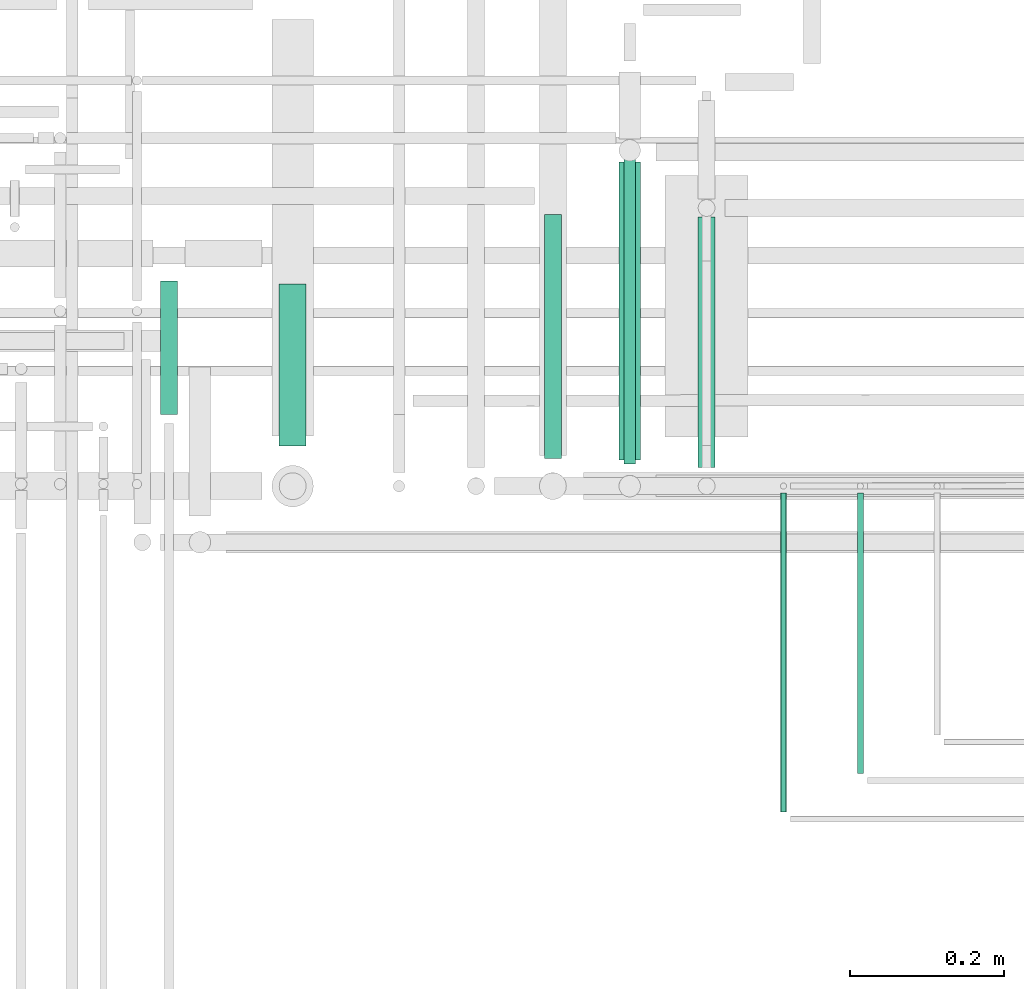
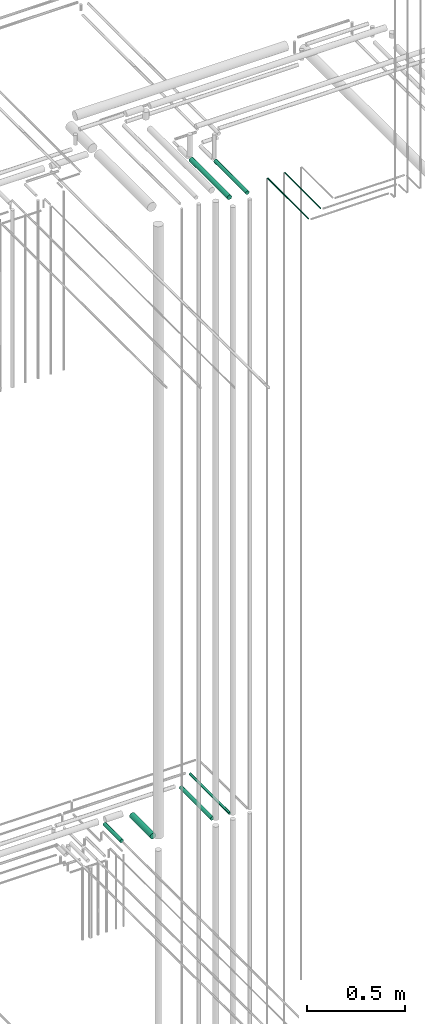
# One storey, part 224 of 331: 8 flow segments.
"""IFC2X3 building model written with IfcOpenShell, lengths in millimetres."""

from ifc_helpers import new_model, entity, si_unit, converted_unit, derived_unit, direction, frame, frame_2d, origin, origin_2d_with_axis, place, context, subcontext, project, spatial, circle, extrude, type_object, element, save


model = new_model("IFC2X3")

# Units and contexts
model_context = context("Model", 3, precision=0.01, world=origin(), true_north=direction((6.12303176911189e-17, 1.0)))
body_context = subcontext(model_context, "Body", "Model", "MODEL_VIEW")
ifc_project = project(units=[si_unit("LENGTHUNIT", "METRE", prefix="MILLI"), si_unit("AREAUNIT", "SQUARE_METRE"), si_unit("VOLUMEUNIT", "CUBIC_METRE"), converted_unit("PLANEANGLEUNIT", "DEGREE", entity("IfcRatioMeasure", 0.0174532925199433), si_unit("PLANEANGLEUNIT", "RADIAN"), dimensions=[0, 0, 0, 0, 0, 0, 0]), si_unit("MASSUNIT", "GRAM", prefix="KILO"), derived_unit("MASSDENSITYUNIT", [(si_unit("MASSUNIT", "GRAM", prefix="KILO"), 1), (si_unit("LENGTHUNIT", "METRE"), -3)]), derived_unit("MOMENTOFINERTIAUNIT", [(si_unit("LENGTHUNIT", "METRE"), 4)]), si_unit("TIMEUNIT", "SECOND"), si_unit("FREQUENCYUNIT", "HERTZ"), si_unit("THERMODYNAMICTEMPERATUREUNIT", "DEGREE_CELSIUS"), derived_unit("THERMALTRANSMITTANCEUNIT", [(si_unit("MASSUNIT", "GRAM", prefix="KILO"), 1), (si_unit("THERMODYNAMICTEMPERATUREUNIT", "KELVIN"), -1), (si_unit("TIMEUNIT", "SECOND"), -3)]), derived_unit("VOLUMETRICFLOWRATEUNIT", [(si_unit("LENGTHUNIT", "METRE"), 3), (si_unit("TIMEUNIT", "SECOND"), -1)]), derived_unit("MASSFLOWRATEUNIT", [(si_unit("MASSUNIT", "GRAM", prefix="KILO"), 1), (si_unit("TIMEUNIT", "SECOND"), -1)]), derived_unit("ROTATIONALFREQUENCYUNIT", [(si_unit("TIMEUNIT", "SECOND"), -1)]), si_unit("ELECTRICCURRENTUNIT", "AMPERE"), si_unit("ELECTRICVOLTAGEUNIT", "VOLT"), si_unit("POWERUNIT", "WATT"), si_unit("FORCEUNIT", "NEWTON", prefix="KILO"), si_unit("ILLUMINANCEUNIT", "LUX"), si_unit("LUMINOUSFLUXUNIT", "LUMEN"), si_unit("LUMINOUSINTENSITYUNIT", "CANDELA"), derived_unit("USERDEFINED", [(si_unit("MASSUNIT", "GRAM", prefix="KILO"), -1), (si_unit("LENGTHUNIT", "METRE"), -2), (si_unit("TIMEUNIT", "SECOND"), 3), (si_unit("LUMINOUSFLUXUNIT", "LUMEN"), 1)]), derived_unit("LINEARVELOCITYUNIT", [(si_unit("LENGTHUNIT", "METRE"), 1), (si_unit("TIMEUNIT", "SECOND"), -1)]), si_unit("PRESSUREUNIT", "PASCAL"), derived_unit("USERDEFINED", [(si_unit("LENGTHUNIT", "METRE"), -2), (si_unit("MASSUNIT", "GRAM", prefix="KILO"), 1), (si_unit("TIMEUNIT", "SECOND"), -2)]), derived_unit("LINEARFORCEUNIT", [(si_unit("MASSUNIT", "GRAM", prefix="KILO"), 1), (si_unit("LENGTHUNIT", "METRE"), 1), (si_unit("TIMEUNIT", "SECOND"), -2), (si_unit("LENGTHUNIT", "METRE"), -1)]), derived_unit("PLANARFORCEUNIT", [(si_unit("MASSUNIT", "GRAM", prefix="KILO"), 1), (si_unit("LENGTHUNIT", "METRE"), 1), (si_unit("TIMEUNIT", "SECOND"), -2), (si_unit("LENGTHUNIT", "METRE"), -2)])], contexts=[model_context])

# Site, building, storey
site_placement = place(None, frame((0.0, -0.00077364408347762, 0.0)))
site = spatial("IfcSite", under=ifc_project, at=site_placement, CompositionType="ELEMENT")
building_placement = place(site_placement, origin())
building = spatial("IfcBuilding", under=site, at=building_placement, CompositionType="ELEMENT")
storey_placement = place(building_placement, origin())
storey = spatial("IfcBuildingStorey", under=building, at=storey_placement, CompositionType="ELEMENT", Elevation=0.0)

# Flow segments
pipe_segment_type = type_object("IfcPipeSegmentType", PredefinedType="NOTDEFINED")
flow_segment_1_placement = place(storey_placement, frame((64142.0166110417, 8176.93026688114, 14540.9047277641)))
element("IfcFlowSegment", 1, at=flow_segment_1_placement, inside=storey, type_object=pipe_segment_type, context=body_context, shape_type="SweptSolid", body=[
    extrude(circle(Radius=7.5, at=frame_2d((0.0, -2.16573425859679e-12), x_axis=(1.0, 0.0))), frame((9.09527223591419, 0.0, 9.09527223591853), z_axis=(0.0, 1.0, 0.0), x_axis=(-1.0, 0.0, 0.0)), (0.0, 0.0, 1.0), 405.690296946231),
])
flow_segment_2_placement = place(storey_placement, frame((64038.5166110417, 8183.93026688113, 14537.4047277641)))
element("IfcFlowSegment", 2, at=flow_segment_2_placement, inside=storey, type_object=pipe_segment_type, context=body_context, shape_type="SweptSolid", body=[
    extrude(circle(Radius=11.0, at=frame_2d((0.0, -2.16573425859679e-12), x_axis=(1.0, 0.0))), frame((12.5952722359134, 0.0, 12.5952722359134), z_axis=(0.0, 1.0, 0.0), x_axis=(1.0, 0.0, 0.0)), (0.0, 0.0, 1.0), 317.69029694623),
])
flow_segment_3_placement = place(storey_placement, frame((63693.5166110417, 8199.93026688114, 14530.9047277641)))
element("IfcFlowSegment", 3, at=flow_segment_3_placement, inside=storey, type_object=pipe_segment_type, context=body_context, shape_type="SweptSolid", body=[
    extrude(circle(Radius=17.5, at=origin_2d_with_axis()), frame((19.0952722359119, 0.0, 19.0952722359163), z_axis=(0.0, 1.0, 0.0), x_axis=(-1.0, 0.0, 0.0)), (0.0, 0.0, 1.0), 210.690296946221),
])
flow_segment_4_placement = place(storey_placement, frame((63539.1958799761, 8241.19160892753, 14537.404727764)))
element("IfcFlowSegment", 4, at=flow_segment_4_placement, inside=storey, type_object=pipe_segment_type, context=body_context, shape_type="SweptSolid", body=[
    extrude(circle(Radius=11.0, at=frame_2d((-2.59888111031614e-11, 0.0), x_axis=(1.0, 0.0))), frame((12.5952722359394, 0.0, 12.5952722359156), z_axis=(0.0, 1.0, 0.0), x_axis=(-1.0, 0.0, 0.0)), (0.0, 0.0, 1.0), 173.428954899822),
])
flow_segment_5_placement = place(storey_placement, frame((64345.5166110417, 7723.90934487776, 18444.4047277641)))
element("IfcFlowSegment", 5, at=flow_segment_5_placement, inside=storey, type_object=pipe_segment_type, context=body_context, shape_type="SweptSolid", body=[
    extrude(circle(Radius=4.0, at=frame_2d((8.66293703438714e-12, 0.0), x_axis=(1.0, 0.0))), frame((5.59527223591499, 0.0, 5.59527223591499), z_axis=(0.0, 1.0, 0.0), x_axis=(-1.0, 0.0, 0.0)), (0.0, 0.0, 1.0), 415.020616439301),
])
flow_segment_6_placement = place(storey_placement, frame((64445.5166110417, 7774.14924977607, 18444.4047277641)))
element("IfcFlowSegment", 6, at=flow_segment_6_placement, inside=storey, type_object=pipe_segment_type, context=body_context, shape_type="SweptSolid", body=[
    extrude(circle(Radius=4.0, at=origin_2d_with_axis()), frame((5.59527223591499, 0.0, 5.59527223591499), z_axis=(0.0, 1.0, 0.0), x_axis=(-1.0, 0.0, 0.0)), (0.0, 0.0, 1.0), 364.78065114625),
])
flow_segment_7_placement = place(storey_placement, frame((64238.5166110417, 8171.93026688112, 18362.4047277641)))
element("IfcFlowSegment", 7, at=flow_segment_7_placement, inside=storey, type_object=pipe_segment_type, context=body_context, shape_type="SweptSolid", body=[
    extrude(circle(Radius=11.0, at=frame_2d((0.0, -2.16573425859679e-12), x_axis=(1.0, 0.0))), frame((12.5952722359134, 0.0, 12.5952722359177), z_axis=(0.0, 1.0, 0.0), x_axis=(-1.0, 0.0, 0.0)), (0.0, 0.0, 1.0), 325.880467601344),
])
flow_segment_8_placement = place(storey_placement, frame((64135.5166110417, 8181.93026688111, 18359.4047277641)))
element("IfcFlowSegment", 8, at=flow_segment_8_placement, inside=storey, type_object=pipe_segment_type, context=body_context, shape_type="SweptSolid", body=[
    extrude(circle(Radius=14.0, at=origin_2d_with_axis()), frame((15.5952722359127, 0.0, 15.5952722359149), z_axis=(0.0, 1.0, 0.0), x_axis=(-1.0, 0.0, 0.0)), (0.0, 0.0, 1.0), 387.880467601359),
])

save(model, "model.ifc")
